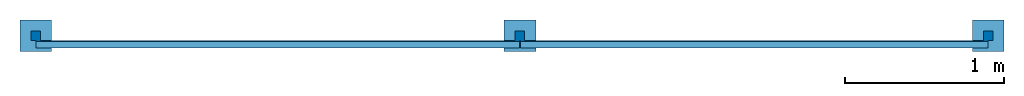
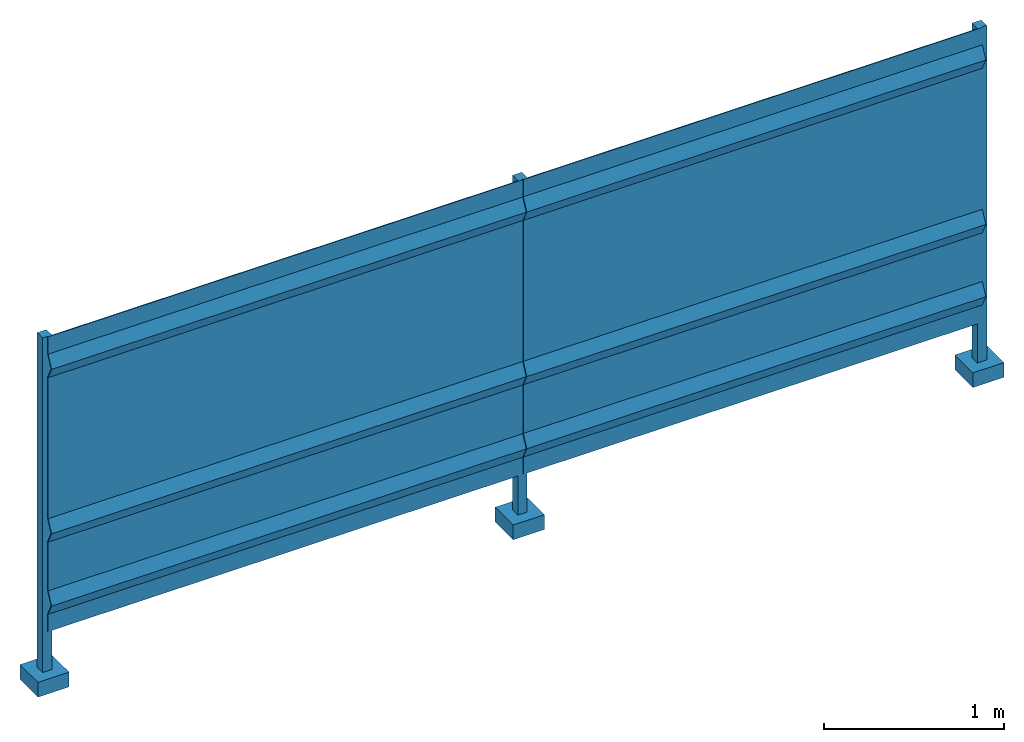
# One storey: 1 wall.
"""IFC2X3 building model written with IfcOpenShell, lengths in millimetres."""

from ifc_helpers import new_model, entity, si_unit, converted_unit, derived_unit, direction, frame, origin, place, context, subcontext, project, spatial, faceted_brep, material, type_object, element, save


model = new_model("IFC2X3")

# Units and contexts
model_context = context("Model", 3, precision=0.01, world=origin(), true_north=direction((6.12303176911189e-17, 1.0)))
body_context = subcontext(model_context, "Body", "Model", "MODEL_VIEW")
ifc_project = project(units=[si_unit("LENGTHUNIT", "METRE", prefix="MILLI"), si_unit("AREAUNIT", "SQUARE_METRE"), si_unit("VOLUMEUNIT", "CUBIC_METRE"), converted_unit("PLANEANGLEUNIT", "DEGREE", entity("IfcRatioMeasure", 0.0174532925199433), si_unit("PLANEANGLEUNIT", "RADIAN"), dimensions=[0, 0, 0, 0, 0, 0, 0]), si_unit("MASSUNIT", "GRAM", prefix="KILO"), derived_unit("MASSDENSITYUNIT", [(si_unit("MASSUNIT", "GRAM", prefix="KILO"), 1), (si_unit("LENGTHUNIT", "METRE"), -3)]), si_unit("TIMEUNIT", "SECOND"), si_unit("FREQUENCYUNIT", "HERTZ"), si_unit("THERMODYNAMICTEMPERATUREUNIT", "DEGREE_CELSIUS"), derived_unit("THERMALTRANSMITTANCEUNIT", [(si_unit("MASSUNIT", "GRAM", prefix="KILO"), 1), (si_unit("THERMODYNAMICTEMPERATUREUNIT", "KELVIN"), -1), (si_unit("TIMEUNIT", "SECOND"), -3)]), derived_unit("VOLUMETRICFLOWRATEUNIT", [(si_unit("LENGTHUNIT", "METRE"), 3), (si_unit("TIMEUNIT", "SECOND"), -1)]), si_unit("ELECTRICCURRENTUNIT", "AMPERE"), si_unit("ELECTRICVOLTAGEUNIT", "VOLT"), si_unit("POWERUNIT", "WATT"), si_unit("FORCEUNIT", "NEWTON", prefix="KILO"), si_unit("ILLUMINANCEUNIT", "LUX"), si_unit("LUMINOUSFLUXUNIT", "LUMEN"), si_unit("LUMINOUSINTENSITYUNIT", "CANDELA"), derived_unit("USERDEFINED", [(si_unit("MASSUNIT", "GRAM", prefix="KILO"), -1), (si_unit("LENGTHUNIT", "METRE"), -2), (si_unit("TIMEUNIT", "SECOND"), 3), (si_unit("LUMINOUSFLUXUNIT", "LUMEN"), 1)]), derived_unit("LINEARVELOCITYUNIT", [(si_unit("LENGTHUNIT", "METRE"), 1), (si_unit("TIMEUNIT", "SECOND"), -1)]), si_unit("PRESSUREUNIT", "PASCAL"), derived_unit("USERDEFINED", [(si_unit("LENGTHUNIT", "METRE"), -2), (si_unit("MASSUNIT", "GRAM", prefix="KILO"), 1), (si_unit("TIMEUNIT", "SECOND"), -2)])], contexts=[model_context])

# Site, building, storey
site_placement = place(None, origin())
site = spatial("IfcSite", under=ifc_project, at=site_placement, CompositionType="ELEMENT")
building_placement = place(site_placement, origin())
building = spatial("IfcBuilding", under=site, at=building_placement, CompositionType="ELEMENT")
storey_placement = place(building_placement, origin())
storey = spatial("IfcBuildingStorey", under=building, at=storey_placement, Name="Level 1", CompositionType="ELEMENT", Elevation=0.0)

# Wall
ifc_material = material()
wall_type = type_object("IfcWallType", PredefinedType="NOTDEFINED", material=ifc_material)
wall_placement = place(storey_placement, frame((-100.0, -100.0, -300.0)))
element("IfcWall", 1, at=wall_placement, inside=storey, type_object=wall_type, material=ifc_material, context=body_context, shape_type="Brep", body=[
    faceted_brep([(3148.0, 64.0, 487.0), (3148.0, 64.0, 370.0), (3148.0, 70.0, 370.0), (3148.0, 70.0, 488.368629060399), (3148.0, 31.6586527353121, 567.0), (3148.0, 70.0, 645.63137093946), (3148.0, 70.0, 978.3686290604), (3148.0, 31.6586527353121, 1057.0), (3148.0, 70.0, 1135.63137093946), (3148.0, 70.0, 2094.3686290604), (3148.0, 31.6586527353121, 2173.0), (3148.0, 70.0, 2251.63137093946), (3148.0, 70.0, 2370.0), (3148.0, 64.0, 2370.0), (3148.0, 64.0, 2253.0), (3148.0, 25.0, 2173.0), (3148.0, 64.0, 2093.0), (3148.0, 64.0, 1137.0), (3148.0, 25.0, 1057.0), (3148.0, 64.0, 977.0), (3148.0, 64.0, 647.0), (3148.0, 25.0, 567.0), (102.0, 64.0, 487.0), (102.0, 64.0, 370.0), (102.0, 70.0, 370.0), (102.0, 70.0, 488.368629060399), (102.0, 31.6586527353121, 567.0), (102.0, 70.0, 645.63137093946), (102.0, 70.0, 978.3686290604), (102.0, 31.6586527353121, 1057.0), (102.0, 70.0, 1135.63137093946), (102.0, 70.0, 2094.3686290604), (102.0, 64.0, 2093.0), (102.0, 64.0, 1137.0), (102.0, 25.0, 1057.0), (102.0, 64.0, 977.0), (102.0, 64.0, 647.0), (102.0, 25.0, 567.0), (102.0, 25.0, 2173.0), (102.0, 64.0, 2253.0), (102.0, 64.0, 2370.0), (102.0, 70.0, 2370.0), (102.0, 70.0, 2251.63137093946), (102.0, 31.6586527353121, 2173.0)], [[[0, 1, 2, 3, 4, 5, 6, 7, 8, 9, 10, 11, 12, 13, 14, 15, 16, 17, 18, 19, 20, 21]], [[1, 0, 22, 23]], [[2, 1, 23, 24]], [[3, 2, 24, 25]], [[4, 3, 25, 26]], [[5, 4, 26, 27]], [[6, 5, 27, 28]], [[7, 6, 28, 29]], [[8, 7, 29, 30]], [[9, 8, 30, 31]], [[17, 16, 32, 33]], [[18, 17, 33, 34]], [[19, 18, 34, 35]], [[20, 19, 35, 36]], [[21, 20, 36, 37]], [[0, 21, 37, 22]], [[22, 37, 36, 35, 34, 33, 32, 38, 39, 40, 41, 42, 43, 31, 30, 29, 28, 27, 26, 25, 24, 23]], [[11, 10, 43, 42]], [[12, 11, 42, 41]], [[13, 12, 41, 40]], [[14, 13, 40, 39]], [[15, 14, 39, 38]], [[10, 9, 31, 43]], [[16, 15, 38, 32]]]),
    faceted_brep([(200.0, 200.0, 100.0), (0.0, 200.0, 100.0), (0.0, 0.0, 100.0), (200.0, 0.0, 100.0), (200.0, 200.0, 0.0), (200.0, 0.0, 0.0), (0.0, 0.0, 0.0), (0.0, 200.0, 0.0)], [[[0, 1, 2, 3]], [[4, 5, 6, 7]], [[1, 0, 4, 7]], [[2, 1, 7, 6]], [[3, 2, 6, 5]], [[0, 3, 5, 4]]]),
    faceted_brep([(130.0, 130.0, 100.0), (130.0, 70.0, 100.0), (70.0, 70.0, 100.0), (70.0, 130.0, 100.0), (130.0, 130.0, 2370.0), (130.0, 70.0, 2370.0), (70.0, 70.0, 2370.0), (70.0, 130.0, 2370.0)], [[[0, 1, 2, 3]], [[4, 5, 1, 0]], [[5, 6, 2, 1]], [[6, 7, 3, 2]], [[7, 4, 0, 3]], [[4, 7, 6, 5]]]),
    faceted_brep([(3250.0, 200.0, 100.0), (3050.0, 200.0, 100.0), (3050.0, 0.0, 100.0), (3250.0, 0.0, 100.0), (3250.0, 200.0, 0.0), (3250.0, 0.0, 0.0), (3050.0, 0.0, 0.0), (3050.0, 200.0, 0.0)], [[[0, 1, 2, 3]], [[4, 5, 6, 7]], [[1, 0, 4, 7]], [[2, 1, 7, 6]], [[3, 2, 6, 5]], [[0, 3, 5, 4]]]),
    faceted_brep([(3180.0, 130.0, 100.0), (3180.0, 70.0, 100.0), (3120.0, 70.0, 100.0), (3120.0, 130.0, 100.0), (3180.0, 130.0, 2370.0), (3180.0, 70.0, 2370.0), (3120.0, 70.0, 2370.0), (3120.0, 130.0, 2370.0)], [[[0, 1, 2, 3]], [[4, 5, 1, 0]], [[5, 6, 2, 1]], [[6, 7, 3, 2]], [[7, 4, 0, 3]], [[4, 7, 6, 5]]]),
    faceted_brep([(6098.0, 64.0, 487.0), (6098.0, 64.0, 370.0), (6098.0, 70.0, 370.0), (6098.0, 70.0, 488.368629060376), (6098.0, 31.6586527352925, 567.0), (6098.0, 70.0, 645.631370939437), (6098.0, 70.0, 978.368629060378), (6098.0, 31.6586527352925, 1057.0), (6098.0, 70.0, 1135.63137093943), (6098.0, 70.0, 2094.36862906038), (6098.0, 31.6586527352925, 2173.0), (6098.0, 70.0, 2251.63137093944), (6098.0, 70.0, 2370.0), (6098.0, 64.0, 2370.0), (6098.0, 64.0, 2253.0), (6098.0, 25.0, 2173.0), (6098.0, 64.0, 2093.0), (6098.0, 64.0, 1137.0), (6098.0, 25.0, 1057.0), (6098.0, 64.0, 977.0), (6098.0, 64.0, 647.0), (6098.0, 25.0, 567.0), (3152.0, 64.0, 487.0), (3152.0, 64.0, 370.0), (3152.0, 70.0, 370.0), (3152.0, 70.0, 488.368629060376), (3152.0, 31.6586527352925, 567.0), (3152.0, 70.0, 645.631370939437), (3152.0, 70.0, 978.368629060378), (3152.0, 31.6586527352925, 1057.0), (3152.0, 70.0, 1135.63137093943), (3152.0, 70.0, 2094.36862906038), (3152.0, 64.0, 2093.0), (3152.0, 64.0, 1137.0), (3152.0, 25.0, 1057.0), (3152.0, 64.0, 977.0), (3152.0, 64.0, 647.0), (3152.0, 25.0, 567.0), (3152.0, 25.0, 2173.0), (3152.0, 64.0, 2253.0), (3152.0, 64.0, 2370.0), (3152.0, 70.0, 2370.0), (3152.0, 70.0, 2251.63137093944), (3152.0, 31.6586527352925, 2173.0)], [[[0, 1, 2, 3, 4, 5, 6, 7, 8, 9, 10, 11, 12, 13, 14, 15, 16, 17, 18, 19, 20, 21]], [[1, 0, 22, 23]], [[2, 1, 23, 24]], [[3, 2, 24, 25]], [[4, 3, 25, 26]], [[5, 4, 26, 27]], [[6, 5, 27, 28]], [[7, 6, 28, 29]], [[8, 7, 29, 30]], [[9, 8, 30, 31]], [[17, 16, 32, 33]], [[18, 17, 33, 34]], [[19, 18, 34, 35]], [[20, 19, 35, 36]], [[21, 20, 36, 37]], [[0, 21, 37, 22]], [[22, 37, 36, 35, 34, 33, 32, 38, 39, 40, 41, 42, 43, 31, 30, 29, 28, 27, 26, 25, 24, 23]], [[11, 10, 43, 42]], [[12, 11, 42, 41]], [[13, 12, 41, 40]], [[14, 13, 40, 39]], [[15, 14, 39, 38]], [[10, 9, 31, 43]], [[16, 15, 38, 32]]]),
    faceted_brep([(6200.0, 200.0, 100.0), (6000.0, 200.0, 100.0), (6000.0, 0.0, 100.0), (6200.0, 0.0, 100.0), (6200.0, 200.0, 0.0), (6200.0, 0.0, 0.0), (6000.0, 0.0, 0.0), (6000.0, 200.0, 0.0)], [[[0, 1, 2, 3]], [[4, 5, 6, 7]], [[1, 0, 4, 7]], [[2, 1, 7, 6]], [[3, 2, 6, 5]], [[0, 3, 5, 4]]]),
    faceted_brep([(6130.0, 130.0, 100.0), (6130.0, 70.0, 100.0), (6070.0, 70.0, 100.0), (6070.0, 130.0, 100.0), (6130.0, 130.0, 2370.0), (6130.0, 70.0, 2370.0), (6070.0, 70.0, 2370.0), (6070.0, 130.0, 2370.0)], [[[0, 1, 2, 3]], [[4, 5, 1, 0]], [[5, 6, 2, 1]], [[6, 7, 3, 2]], [[7, 4, 0, 3]], [[4, 7, 6, 5]]]),
])

save(model, "model.ifc")
